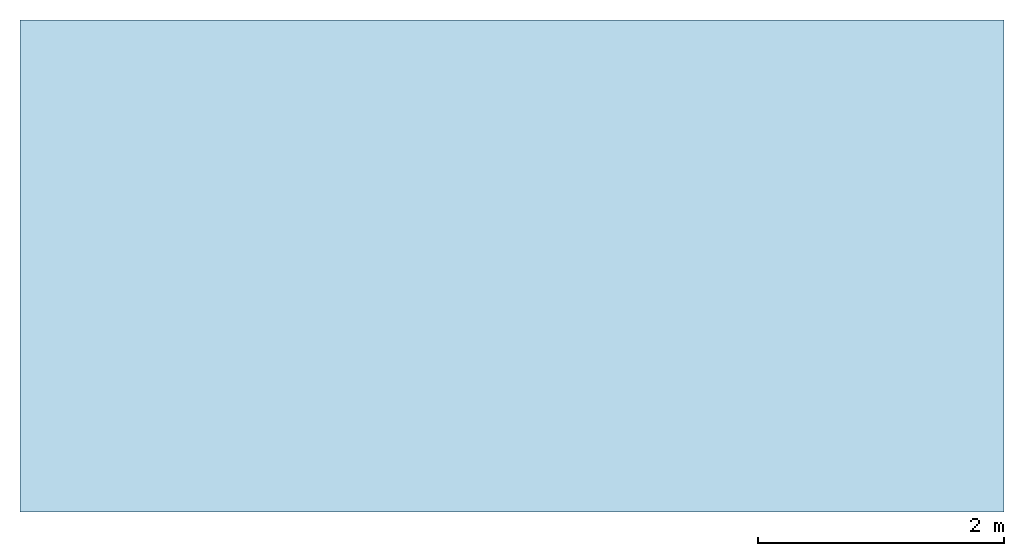
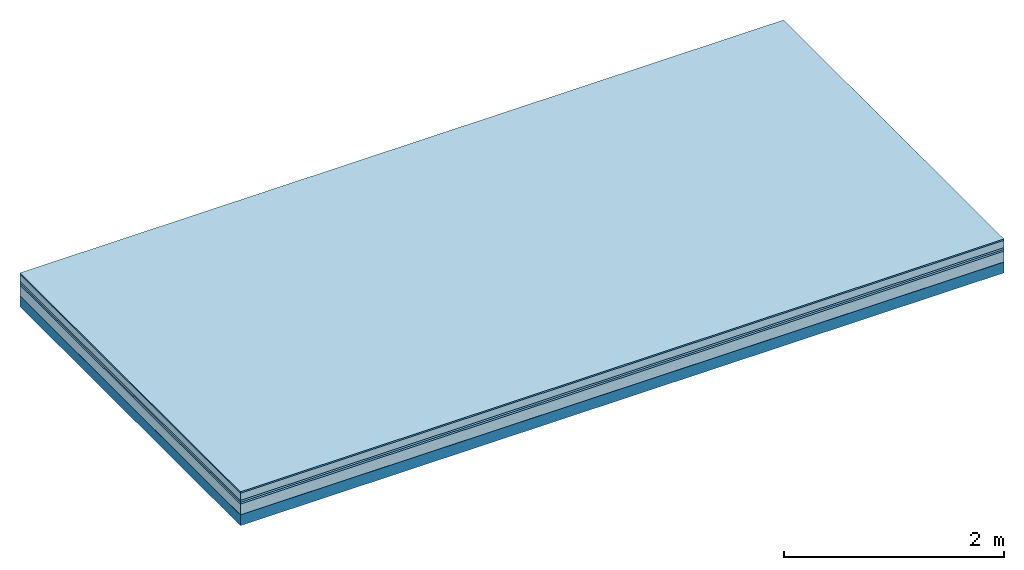
# One storey: 6 plates, 1 member, 1 element without a shape of its own.
"""IFC4 building model written with IfcOpenShell, lengths in metres."""

import ifcopenshell
import ifcopenshell.guid

model = None  # the IFC model being written
_history = None  # IfcOwnerHistory: only IFC2X3 demands one
_inside = {}  # id of a spatial element -> (the spatial element, [elements in it])
_under = {}  # id of a project, library or spatial element -> (it, [spatial elements below it])
_declared = {}  # id of a project -> (the project, [libraries it declares])
_typed = {}  # id of a type object -> (the type object, [elements of that type])
_made_of = {}  # id of a material, layer set ... -> (it, [elements and type objects made of it])


def new_model(schema):
    """Start an empty IFC model of exactly this schema.

    Asked for "IFC4X3", IfcOpenShell would pick the latest addendum, in which some entities
    have other attributes; the version numbers below select the first issue.
    IFC2X3 requires an IfcOwnerHistory on every rooted entity: one is made here for all.
    """
    global model, _history
    if schema == "IFC4X3":
        model = ifcopenshell.file(schema_version=(4, 3, 0, 0))
    else:
        model = ifcopenshell.file(schema=schema)
    _inside.clear()
    _under.clear()
    _declared.clear()
    _typed.clear()
    _made_of.clear()
    _history = None
    if model.schema == "IFC2X3":
        org = make("IfcOrganization", Name="unknown")
        user = make(
            "IfcPersonAndOrganization",
            ThePerson=make("IfcPerson", FamilyName="unknown"),
            TheOrganization=org,
        )
        app = make(
            "IfcApplication",
            ApplicationDeveloper=org,
            Version="unknown",
            ApplicationFullName="unknown",
            ApplicationIdentifier="unknown",
        )
        _history = make(
            "IfcOwnerHistory",
            OwningUser=user,
            OwningApplication=app,
            ChangeAction="ADDED",
            CreationDate=0,
        )
    return model


def make(cls, **values):
    """One entity of the class cls with the attributes given. An attribute that is None is left unset."""
    return model.create_entity(
        cls, **{name: value for name, value in values.items() if value is not None}
    )


def rooted(cls, **values):
    """An entity with a GlobalId (a new one), such as an element, a storey or a relation."""
    return make(cls, GlobalId=ifcopenshell.guid.new(), OwnerHistory=_history, **values)


def si_unit(unit_type, name, prefix=None):
    """IfcSIUnit, for example si_unit("LENGTHUNIT", "METRE", prefix="MILLI")."""
    return make("IfcSIUnit", UnitType=unit_type, Prefix=prefix, Name=name)


def derived_unit(unit_type, elements):
    """IfcDerivedUnit: a product of units, each with its exponent."""
    return make(
        "IfcDerivedUnit",
        Elements=[
            make("IfcDerivedUnitElement", Unit=unit, Exponent=power)
            for unit, power in elements
        ],
        UnitType=unit_type,
    )


def assignment(units):
    """IfcUnitAssignment: the units of a project."""
    return None if units is None else make("IfcUnitAssignment", Units=units)


def point(xyz):
    """IfcCartesianPoint."""
    return None if xyz is None else make("IfcCartesianPoint", Coordinates=xyz)


def direction(xyz):
    """IfcDirection."""
    return None if xyz is None else make("IfcDirection", DirectionRatios=xyz)


def frame(location, z_axis=None, x_axis=None):
    """IfcAxis2Placement3D, a coordinate frame: its origin and axes. An axis left out is left unset."""
    return make(
        "IfcAxis2Placement3D",
        Location=point(location),
        Axis=direction(z_axis),
        RefDirection=direction(x_axis),
    )


def frame_2d(location, x_axis=None):
    """IfcAxis2Placement2D, a coordinate frame in the plane: its origin and x axis."""
    return make(
        "IfcAxis2Placement2D", Location=point(location), RefDirection=direction(x_axis)
    )


def origin():
    """The frame at (0, 0, 0) with its axes left unset."""
    return frame((0.0, 0.0, 0.0))


def origin_with_axes():
    """The frame at (0, 0, 0) with the z axis (0, 0, 1) and the x axis (1, 0, 0) written out."""
    return frame((0.0, 0.0, 0.0), z_axis=(0.0, 0.0, 1.0), x_axis=(1.0, 0.0, 0.0))


def place(relative_to, where):
    """IfcLocalPlacement: puts the frame where relative to a parent placement (None: the world)."""
    return make(
        "IfcLocalPlacement", PlacementRelTo=relative_to, RelativePlacement=where
    )


def context(
    kind, dimensions, precision=None, world=None, true_north=None, identifier=None
):
    """IfcGeometricRepresentationContext, for example the 3D "Model" context."""
    return make(
        "IfcGeometricRepresentationContext",
        ContextIdentifier=identifier,
        ContextType=kind,
        CoordinateSpaceDimension=dimensions,
        Precision=precision,
        WorldCoordinateSystem=world,
        TrueNorth=true_north,
    )


def project(units=None, contexts=None):
    """IfcProject with its units and contexts."""
    return rooted(
        "IfcProject",
        Name="project",
        RepresentationContexts=contexts,
        UnitsInContext=assignment(units),
    )


def spatial(cls, under=None, at=None, **own):
    """A site, building, storey or space (cls), placed at a placement, below another one or the project."""
    s = rooted(cls, ObjectPlacement=at, **own)
    if under is not None:
        _under.setdefault(under.id(), (under, []))[1].append(s)
    return s


def profile(cls, at=None, kind="AREA", **sizes):
    """A parametric profile (cls). Its sizes go by their IFC names, for example OverallWidth=200.0."""
    return make(cls, ProfileType=kind, Position=at, **sizes)


def rectangle(**sizes):
    """IfcRectangleProfileDef."""
    return profile("IfcRectangleProfileDef", **sizes)


def extrude(swept, where, along, depth):
    """IfcExtrudedAreaSolid: the profile swept, set in the frame where, extruded along a direction by depth."""
    return make(
        "IfcExtrudedAreaSolid",
        SweptArea=swept,
        Position=where,
        ExtrudedDirection=direction(along),
        Depth=depth,
    )


def shape(context_of_items, identifier, shape_type, items):
    """IfcShapeRepresentation: the items that make up one representation, for example the "Body"."""
    return make(
        "IfcShapeRepresentation",
        ContextOfItems=context_of_items,
        RepresentationIdentifier=identifier,
        RepresentationType=shape_type,
        Items=items,
    )


def material(Name=None, Category=None):
    """IfcMaterial."""
    return make("IfcMaterial", Name=Name, Category=Category)


def layer(
    of_material, thickness, ventilated=None, Name=None, Category=None, Priority=None
):
    """IfcMaterialLayer: one layer of a wall or slab, of a material (None: an air gap)."""
    return make(
        "IfcMaterialLayer",
        Material=of_material,
        LayerThickness=thickness,
        IsVentilated=ventilated,
        Name=Name,
        Category=Category,
        Priority=Priority,
    )


def layer_set(layers, Name=None):
    """IfcMaterialLayerSet."""
    return make("IfcMaterialLayerSet", MaterialLayers=layers, LayerSetName=Name)


def made_of(thing, what):
    """Note that an element or type object is made of a material, layer set ...; save() writes the relation."""
    if what is not None:
        _made_of.setdefault(what.id(), (what, []))[1].append(thing)
    return thing


def type_object(cls, material=None, **own):
    """A type object (cls), such as IfcWallType, which elements share."""
    return made_of(rooted(cls, **own), material)


def element(
    cls,
    number,
    at=None,
    inside=None,
    cuts=None,
    type_object=None,
    material=None,
    context=None,
    identifier="Body",
    shape_type=None,
    held_by="IfcProductDefinitionShape",
    body=None,
    shapes=None,
    **own,
):
    """One element of the class cls, such as IfcWall. Its Tag is "e" and its number.

    at: its placement. inside: the storey or other place that contains it. cuts: it is an
    opening in that element (IfcRelVoidsElement). A single representation is given by context,
    identifier, shape_type and body (its items); several are given by shapes. held_by: the class
    of the entity that holds the representations. save() writes the other relations.
    """
    e = rooted(cls, Tag="e%d" % number, ObjectPlacement=at, **own)
    if body is not None:
        shapes = [shape(context, identifier, shape_type, body)]
    if shapes is not None:
        e.Representation = make(held_by, Representations=shapes)
    if inside is not None:
        _inside.setdefault(inside.id(), (inside, []))[1].append(e)
    if cuts is not None:
        rooted(
            "IfcRelVoidsElement", RelatingBuildingElement=cuts, RelatedOpeningElement=e
        )
    if type_object is not None:
        _typed.setdefault(type_object.id(), (type_object, []))[1].append(e)
    return made_of(e, material)


def aggregate(whole, parts):
    """IfcRelAggregates: a whole, such as a stair, and the parts it consists of."""
    return rooted("IfcRelAggregates", RelatingObject=whole, RelatedObjects=parts)


def save(model, path):
    """Write the relations noted so far, then the file.

    IfcRelAggregates (storeys below a building ...), IfcRelContainedInSpatialStructure (elements
    in a storey), IfcRelDefinesByType, IfcRelAssociatesMaterial and IfcRelDeclares: one each for
    every whole, place, type object, material and project.
    """
    for whole, parts in _under.values():
        aggregate(whole, parts)
    for where, things in _inside.values():
        rooted(
            "IfcRelContainedInSpatialStructure",
            RelatedElements=things,
            RelatingStructure=where,
        )
    for kind, things in _typed.values():
        rooted("IfcRelDefinesByType", RelatedObjects=things, RelatingType=kind)
    for what, things in _made_of.values():
        rooted("IfcRelAssociatesMaterial", RelatedObjects=things, RelatingMaterial=what)
    for by, libraries in _declared.values():
        rooted("IfcRelDeclares", RelatingContext=by, RelatedDefinitions=libraries)
    model.write(path)


model = new_model("IFC4")

# Units and contexts
plan_context = context("Plan", 3, precision=1e-05, world=origin(), true_north=direction((0.0, 1.0)))
model_context = context("Model", 3, precision=1e-05, world=origin(), true_north=direction((0.0, 1.0)))
ifc_project = project(units=[si_unit("LENGTHUNIT", "METRE"), derived_unit("SOUNDPRESSUREUNIT", [(si_unit("PRESSUREUNIT", "PASCAL", prefix="MICRO"), 0)]), si_unit("ENERGYUNIT", "JOULE", prefix="MEGA"), si_unit("MASSUNIT", "GRAM", prefix="KILO"), derived_unit("THERMALTRANSMITTANCEUNIT", [(si_unit("POWERUNIT", "WATT"), 1), (si_unit("AREAUNIT", "SQUARE_METRE"), -1), (si_unit("THERMODYNAMICTEMPERATUREUNIT", "KELVIN"), -1)]), derived_unit("AREADENSITYUNIT", [(si_unit("MASSUNIT", "GRAM", prefix="KILO"), 1), (si_unit("AREAUNIT", "SQUARE_METRE"), -1)]), derived_unit("USERDEFINED", [(si_unit("ENERGYUNIT", "JOULE", prefix="MEGA"), 1), (si_unit("AREAUNIT", "SQUARE_METRE"), -1)])], contexts=[plan_context, model_context])

# Site, building, storey
site = spatial("IfcSite", under=ifc_project)
building_placement = place(None, origin())
building = spatial("IfcBuilding", under=site, at=building_placement)
storey_placement = place(building_placement, origin())
storey = spatial("IfcBuildingStorey", under=building, at=storey_placement)

# Slab, member, plates
ifc_material_1 = material(Category="11.013")
ifc_layer_1 = layer(ifc_material_1, 0.015, Name="Flooring")
ifc_material_2 = material(Name="Cement screed", Category="04.006")
ifc_layer_2 = layer(ifc_material_2, 0.08, Name="On-material")
ifc_material_3 = material(Name="Wood fiber generic product", Category="10.009")
ifc_layer_3 = layer(ifc_material_3, 0.02, Name="Impact sound insulation")
ifc_material_4 = material()
ifc_layer_4 = layer(ifc_material_4, 0.02, Name="Additional insulation")
ifc_material_5 = material(Category="03.011")
ifc_layer_5 = layer(ifc_material_5, 0.12, Name="on Supporting structure")
ifc_material_6 = material(Name="protection", Category="09.007")
ifc_layer_6 = layer(ifc_material_6, 0.0005, Name="Sub-floor")
ifc_material_7 = material(Name="no composite action")
ifc_layer_7 = layer(ifc_material_7, 0.0, Name="Bond")
ifc_layer_8 = layer(None, 0.12, Name="Supporting structure")
ifc_layer_set = layer_set([ifc_layer_1, ifc_layer_2, ifc_layer_3, ifc_layer_4, ifc_layer_5, ifc_layer_6, ifc_layer_7, ifc_layer_8])
slab_type = type_object("IfcSlabType", Name="A2078", PredefinedType="NOTDEFINED", material=ifc_layer_set)
slab_placement = place(None, frame((0.0, 0.0, 0.0), z_axis=(0.0, 0.0, -1.0), x_axis=(1.0, 0.0, 0.0)))
slab = element("IfcSlab", 1, at=slab_placement, inside=storey, type_object=slab_type, material=ifc_layer_set, Name="Slab #1")
ifc_material_8 = material(Name="Solid timber panel")
member_placement = place(slab_placement, origin())
member = element("IfcMember", 2, at=member_placement, material=ifc_material_8, Name="Supporting structure", context=plan_context, shape_type="SweptSolid", body=[
    extrude(rectangle(XDim=1.0, YDim=0.12, at=frame_2d((0.5, 0.06), x_axis=(1.0, 0.0))), frame((0.0, 4.0, 0.2555), z_axis=(0.0, -1.0, 0.0), x_axis=(1.0, 0.0, 0.0)), (0.0, 0.0, 1.0), 4.0),
    extrude(rectangle(XDim=1.0, YDim=0.12, at=frame_2d((0.5, 0.06), x_axis=(1.0, 0.0))), frame((1.0, 4.0, 0.2555), z_axis=(0.0, -1.0, 0.0), x_axis=(1.0, 0.0, 0.0)), (0.0, 0.0, 1.0), 4.0),
    extrude(rectangle(XDim=1.0, YDim=0.12, at=frame_2d((0.5, 0.06), x_axis=(1.0, 0.0))), frame((2.0, 4.0, 0.2555), z_axis=(0.0, -1.0, 0.0), x_axis=(1.0, 0.0, 0.0)), (0.0, 0.0, 1.0), 4.0),
    extrude(rectangle(XDim=1.0, YDim=0.12, at=frame_2d((0.5, 0.06), x_axis=(1.0, 0.0))), frame((3.0, 4.0, 0.2555), z_axis=(0.0, -1.0, 0.0), x_axis=(1.0, 0.0, 0.0)), (0.0, 0.0, 1.0), 4.0),
    extrude(rectangle(XDim=1.0, YDim=0.12, at=frame_2d((0.5, 0.06), x_axis=(1.0, 0.0))), frame((4.0, 4.0, 0.2555), z_axis=(0.0, -1.0, 0.0), x_axis=(1.0, 0.0, 0.0)), (0.0, 0.0, 1.0), 4.0),
    extrude(rectangle(XDim=1.0, YDim=0.12, at=frame_2d((0.5, 0.06), x_axis=(1.0, 0.0))), frame((5.0, 4.0, 0.2555), z_axis=(0.0, -1.0, 0.0), x_axis=(1.0, 0.0, 0.0)), (0.0, 0.0, 1.0), 4.0),
    extrude(rectangle(XDim=1.0, YDim=0.12, at=frame_2d((0.5, 0.06), x_axis=(1.0, 0.0))), frame((6.0, 4.0, 0.2555), z_axis=(0.0, -1.0, 0.0), x_axis=(1.0, 0.0, 0.0)), (0.0, 0.0, 1.0), 4.0),
    extrude(rectangle(XDim=1.0, YDim=0.12, at=frame_2d((0.5, 0.06), x_axis=(1.0, 0.0))), frame((7.0, 4.0, 0.2555), z_axis=(0.0, -1.0, 0.0), x_axis=(1.0, 0.0, 0.0)), (0.0, 0.0, 1.0), 4.0),
])
plate_1_placement = place(slab_placement, origin())
plate_1 = element("IfcPlate", 3, at=plate_1_placement, material=ifc_material_1, Name="Flooring", context=plan_context, shape_type="SweptSolid", body=[
    extrude(rectangle(XDim=8.0, YDim=4.0, at=frame_2d((4.0, 2.0), x_axis=(1.0, 0.0))), origin_with_axes(), (0.0, 0.0, 1.0), 0.015),
])
plate_2_placement = place(slab_placement, origin())
plate_2 = element("IfcPlate", 4, at=plate_2_placement, material=ifc_material_2, Name="On-material", context=plan_context, shape_type="SweptSolid", body=[
    extrude(rectangle(XDim=8.0, YDim=4.0, at=frame_2d((4.0, 2.0), x_axis=(1.0, 0.0))), frame((0.0, 0.0, 0.015), z_axis=(0.0, 0.0, 1.0), x_axis=(1.0, 0.0, 0.0)), (0.0, 0.0, 1.0), 0.08),
])
plate_3_placement = place(slab_placement, origin())
plate_3 = element("IfcPlate", 5, at=plate_3_placement, material=ifc_material_3, Name="Impact sound insulation", context=plan_context, shape_type="SweptSolid", body=[
    extrude(rectangle(XDim=8.0, YDim=4.0, at=frame_2d((4.0, 2.0), x_axis=(1.0, 0.0))), frame((0.0, 0.0, 0.095), z_axis=(0.0, 0.0, 1.0), x_axis=(1.0, 0.0, 0.0)), (0.0, 0.0, 1.0), 0.02),
])
plate_4_placement = place(slab_placement, origin())
plate_4 = element("IfcPlate", 6, at=plate_4_placement, material=ifc_material_4, Name="Additional insulation", context=plan_context, shape_type="SweptSolid", body=[
    extrude(rectangle(XDim=8.0, YDim=4.0, at=frame_2d((4.0, 2.0), x_axis=(1.0, 0.0))), frame((0.0, 0.0, 0.115), z_axis=(0.0, 0.0, 1.0), x_axis=(1.0, 0.0, 0.0)), (0.0, 0.0, 1.0), 0.02),
])
plate_5_placement = place(slab_placement, origin())
plate_5 = element("IfcPlate", 7, at=plate_5_placement, material=ifc_material_5, Name="on Supporting structure", context=plan_context, shape_type="SweptSolid", body=[
    extrude(rectangle(XDim=8.0, YDim=4.0, at=frame_2d((4.0, 2.0), x_axis=(1.0, 0.0))), frame((0.0, 0.0, 0.135), z_axis=(0.0, 0.0, 1.0), x_axis=(1.0, 0.0, 0.0)), (0.0, 0.0, 1.0), 0.12),
])
plate_6_placement = place(slab_placement, origin())
plate_6 = element("IfcPlate", 8, at=plate_6_placement, material=ifc_material_6, Name="Sub-floor", context=plan_context, shape_type="SweptSolid", body=[
    extrude(rectangle(XDim=8.0, YDim=4.0, at=frame_2d((4.0, 2.0), x_axis=(1.0, 0.0))), frame((0.0, 0.0, 0.255), z_axis=(0.0, 0.0, 1.0), x_axis=(1.0, 0.0, 0.0)), (0.0, 0.0, 1.0), 0.0005),
])
aggregate(slab, [plate_1, plate_2, plate_3, plate_4, plate_5, plate_6, member])

save(model, "model.ifc")
